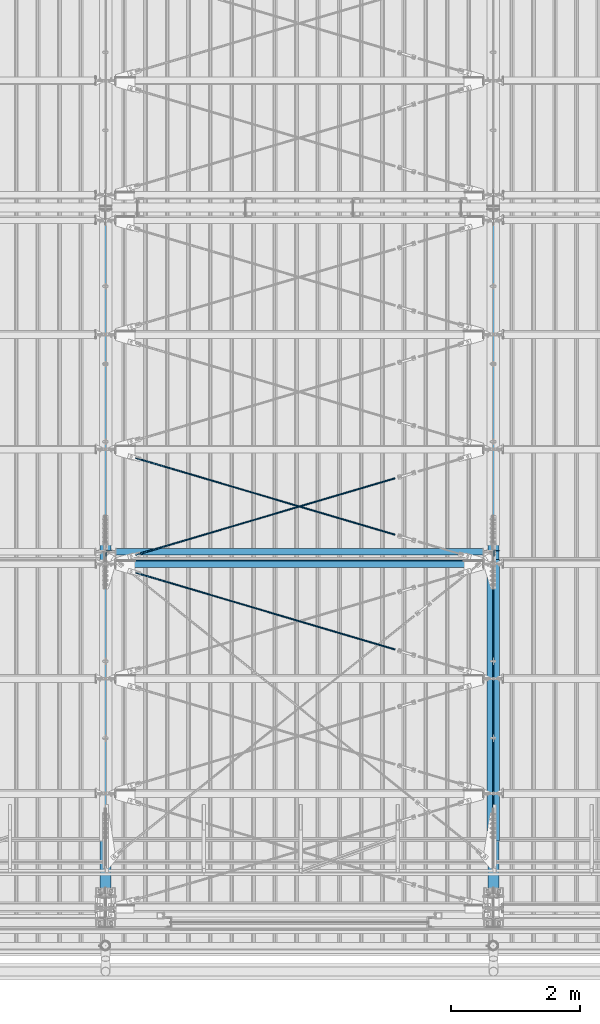
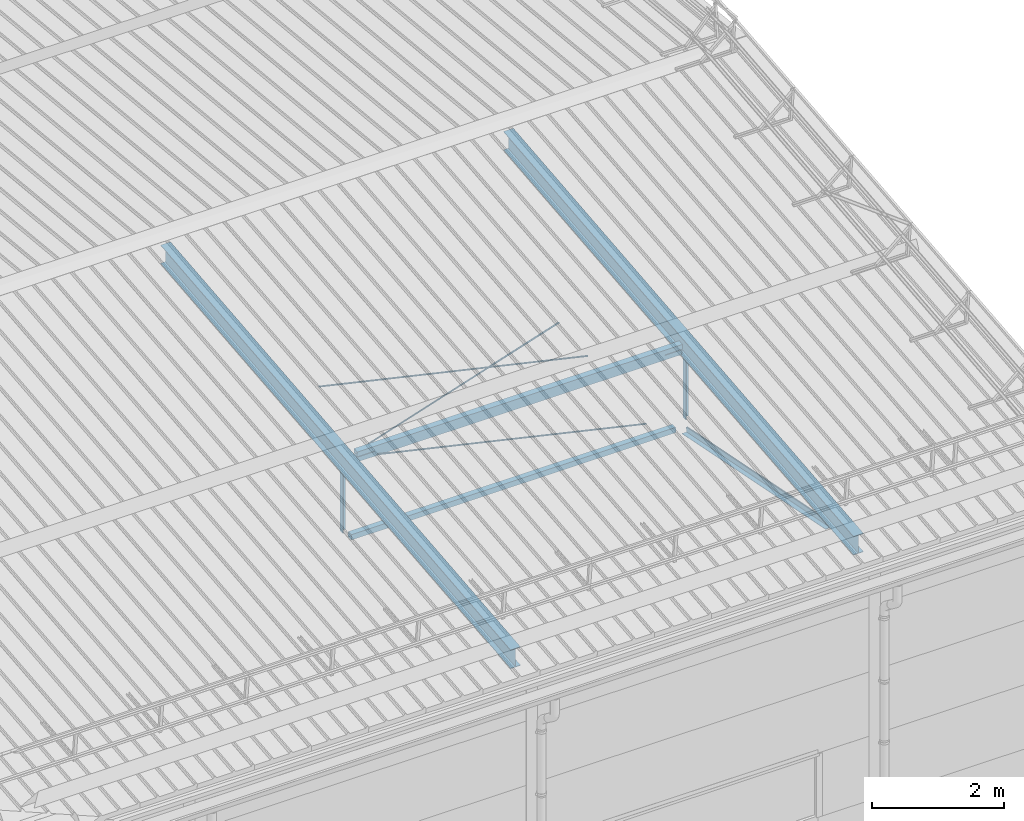
# One storey, part 275 of 709: 11 beams, 5 openings, 11 elements without a shape of their own.
"""IFC4 building model written with IfcOpenShell, lengths in millimetres."""

from ifc_helpers import new_model, si_unit, direction, frame, origin_with_axes, place, context, subcontext, project, spatial, line, indexed_curve, outline, extrude, polygons, material, element, aggregate, save


model = new_model("IFC4")

# Units and contexts
model_context = context("Model", 3, precision=0.2, world=origin_with_axes(), true_north=direction((0.0, 1.0)))
body_context = subcontext(model_context, "Body", "Model", "MODEL_VIEW")
reference_context = subcontext(model_context, "Reference", "Model", "MODEL_VIEW")
ifc_project = project(units=[si_unit("LENGTHUNIT", "METRE", prefix="MILLI"), si_unit("AREAUNIT", "SQUARE_METRE"), si_unit("VOLUMEUNIT", "CUBIC_METRE"), si_unit("MASSUNIT", "GRAM", prefix="KILO"), si_unit("TIMEUNIT", "SECOND"), si_unit("PLANEANGLEUNIT", "RADIAN"), si_unit("SOLIDANGLEUNIT", "STERADIAN"), si_unit("THERMODYNAMICTEMPERATUREUNIT", "DEGREE_CELSIUS"), si_unit("LUMINOUSINTENSITYUNIT", "LUMEN")], contexts=[model_context])

# Site, building, storey
site_placement = place(None, origin_with_axes())
site = spatial("IfcSite", under=ifc_project, at=site_placement, CompositionType="ELEMENT")
building_placement = place(site_placement, origin_with_axes())
building = spatial("IfcBuilding", under=site, at=building_placement, Name="Undefined", CompositionType="ELEMENT")
storey_placement = place(building_placement, origin_with_axes())
storey = spatial("IfcBuildingStorey", under=building, at=storey_placement, Name="Undefined", CompositionType="ELEMENT", Elevation=0.0)

# Assembly, beam
assembly_1_placement = place(storey_placement, frame((40000.0, 346.0, 7089.70002), z_axis=(1.0, 0.0, 0.0), x_axis=(0.0, 0.9950371902, 0.099503719)))
assembly_1 = element("IfcElementAssembly", 1, at=assembly_1_placement, inside=storey)
ifc_material_1 = material(Name="C355-5", Category="STEEL")
beam_1_placement = place(assembly_1_placement, origin_with_axes())
beam_1 = element("IfcBeam", 2, at=beam_1_placement, material=ifc_material_1, ObjectType="432", context=body_context, shape_type="Tessellation", body=[
    polygons([(3.80474, -173.0, -87.0), (4.70474, -164.0, -87.0), (10665.6128, -164.0, -87.0), (10664.7128, -173.0, -87.0), (4.70474, -164.0, -3.0), (10665.6128, -164.0, -3.0), (37.50474, 164.0, -3.0), (10698.4128, 164.0, -3.0), (37.50474, 164.0, -87.0), (10698.4128, 164.0, -87.0), (38.40474, 173.0, -87.0), (10699.3128, 173.0, -87.0), (38.40474, 173.0, 87.0), (10699.3128, 173.0, 87.0), (37.50474, 164.0, 87.0), (10698.4128, 164.0, 87.0), (37.50474, 164.0, 3.0), (10698.4128, 164.0, 3.0), (4.70474, -164.0, 3.0), (10665.6128, -164.0, 3.0), (4.70474, -164.0, 87.0), (10665.6128, -164.0, 87.0), (3.80474, -173.0, 87.0), (10664.7128, -173.0, 87.0)], [[[1, 2, 3, 4]], [[2, 5, 6, 3]], [[5, 7, 8, 6]], [[7, 9, 10, 8]], [[9, 11, 12, 10]], [[11, 13, 14, 12]], [[13, 15, 16, 14]], [[15, 17, 18, 16]], [[17, 19, 20, 18]], [[19, 21, 22, 20]], [[21, 23, 24, 22]], [[23, 1, 4, 24]], [[6, 8, 10, 12, 14, 16, 18, 20, 22, 24, 4, 3]], [[23, 21, 19, 17, 15, 13, 11, 9, 7, 5, 2, 1]]], closed=True),
])
aggregate(assembly_1, [beam_1])

assembly_2_placement = place(storey_placement, frame((40051.0, 5648.7, 7622.40002), z_axis=(0.0, -1.0, 0.0), x_axis=(0.0, 0.0, -1.0)))
assembly_2 = element("IfcElementAssembly", 3, at=assembly_2_placement, inside=storey)
ifc_material_2 = material(Name="C345-5", Category="STEEL")
beam_2_placement = place(assembly_2_placement, origin_with_axes())
beam_2 = element("IfcBeam", 4, at=beam_2_placement, material=ifc_material_2, ObjectType="436", context=body_context, shape_type="Tessellation", body=[
    polygons([(199.0491, -45.0, -45.0), (199.0491, 45.0, -45.0), (1412.4, 45.0, -45.0), (1412.4, -45.0, -45.0), (199.0491, 45.0, -39.0), (1412.4, 45.0, -39.0), (199.0491, -39.0, -39.0), (1412.4, -39.0, -39.0), (199.0491, -39.0, 45.0), (1412.4, -39.0, 45.0), (199.0491, -45.0, 45.0), (1412.4, -45.0, 45.0)], [[[1, 2, 3, 4]], [[2, 5, 6, 3]], [[5, 7, 8, 6]], [[7, 9, 10, 8]], [[9, 11, 12, 10]], [[11, 1, 4, 12]], [[6, 8, 10, 12, 4, 3]], [[11, 9, 7, 5, 2, 1]]], closed=True),
])
aggregate(assembly_2, [beam_2])

assembly_3_placement = place(storey_placement, frame((46000.0, 346.0, 7089.70002), z_axis=(1.0, 0.0, 0.0), x_axis=(0.0, 0.9950371902, 0.099503719)))
assembly_3 = element("IfcElementAssembly", 5, at=assembly_3_placement, inside=storey)
beam_3_placement = place(assembly_3_placement, origin_with_axes())
beam_3 = element("IfcBeam", 6, at=beam_3_placement, material=ifc_material_1, ObjectType="432", context=body_context, shape_type="Tessellation", body=[
    polygons([(3.80474, -173.0, -87.0), (4.70474, -164.0, -87.0), (10665.6128, -164.0, -87.0), (10664.7128, -173.0, -87.0), (4.70474, -164.0, -3.0), (10665.6128, -164.0, -3.0), (37.50474, 164.0, -3.0), (10698.4128, 164.0, -3.0), (37.50474, 164.0, -87.0), (10698.4128, 164.0, -87.0), (38.40474, 173.0, -87.0), (10699.3128, 173.0, -87.0), (38.40474, 173.0, 87.0), (10699.3128, 173.0, 87.0), (37.50474, 164.0, 87.0), (10698.4128, 164.0, 87.0), (37.50474, 164.0, 3.0), (10698.4128, 164.0, 3.0), (4.70474, -164.0, 3.0), (10665.6128, -164.0, 3.0), (4.70474, -164.0, 87.0), (10665.6128, -164.0, 87.0), (3.80474, -173.0, 87.0), (10664.7128, -173.0, 87.0)], [[[1, 2, 3, 4]], [[2, 5, 6, 3]], [[5, 7, 8, 6]], [[7, 9, 10, 8]], [[9, 11, 12, 10]], [[11, 13, 14, 12]], [[13, 15, 16, 14]], [[15, 17, 18, 16]], [[17, 19, 20, 18]], [[19, 21, 22, 20]], [[21, 23, 24, 22]], [[23, 1, 4, 24]], [[6, 8, 10, 12, 14, 16, 18, 20, 22, 24, 4, 3]], [[23, 21, 19, 17, 15, 13, 11, 9, 7, 5, 2, 1]]], closed=True),
])
aggregate(assembly_3, [beam_3])

assembly_4_placement = place(storey_placement, frame((45949.0, 350.0596, 7109.99804), z_axis=(0.0, 0.1961161349, 0.9805806757), x_axis=(0.0, 0.9805806757, -0.1961161349)))
assembly_4 = element("IfcElementAssembly", 7, at=assembly_4_placement, inside=storey)
beam_4_placement = place(assembly_4_placement, origin_with_axes())
beam_4 = element("IfcBeam", 8, at=beam_4_placement, material=ifc_material_2, ObjectType="435", context=body_context, shape_type="Tessellation", body=[
    polygons([(873.96605, -45.0, -45.0), (873.96605, 45.0, -45.0), (5317.375, 45.0, -45.0), (5317.375, -45.0, -45.0), (873.96605, 45.0, -39.0), (5317.375, 45.0, -39.0), (873.96605, -39.0, -39.0), (5317.375, -39.0, -39.0), (873.96605, -39.0, 45.0), (5317.375, -39.0, 45.0), (873.96605, -45.0, 45.0), (5317.375, -45.0, 45.0)], [[[1, 2, 3, 4]], [[2, 5, 6, 3]], [[5, 7, 8, 6]], [[7, 9, 10, 8]], [[9, 11, 12, 10]], [[11, 1, 4, 12]], [[6, 8, 10, 12, 4, 3]], [[11, 9, 7, 5, 2, 1]]], closed=True),
])
aggregate(assembly_4, [beam_4])

assembly_5_placement = place(storey_placement, frame((46051.0, 5677.0596, 6044.59804), z_axis=(0.0, 0.1961161349, 0.9805806757), x_axis=(0.0, -0.9805806757, 0.1961161349)))
assembly_5 = element("IfcElementAssembly", 9, at=assembly_5_placement, inside=storey)
beam_5_placement = place(assembly_5_placement, origin_with_axes())
beam_5 = element("IfcBeam", 10, at=beam_5_placement, material=ifc_material_2, ObjectType="435", context=body_context, shape_type="Tessellation", body=[
    polygons([(115.12039, -45.0, -45.0), (115.12039, 45.0, -45.0), (4558.52934, 45.0, -45.0), (4558.52934, -45.0, -45.0), (115.12039, 45.0, -39.0), (4558.52934, 45.0, -39.0), (115.12039, -39.0, -39.0), (4558.52934, -39.0, -39.0), (115.12039, -39.0, 45.0), (4558.52934, -39.0, 45.0), (115.12039, -45.0, 45.0), (4558.52934, -45.0, 45.0)], [[[1, 2, 3, 4]], [[2, 5, 6, 3]], [[5, 7, 8, 6]], [[7, 9, 10, 8]], [[9, 11, 12, 10]], [[11, 1, 4, 12]], [[6, 8, 10, 12, 4, 3]], [[11, 9, 7, 5, 2, 1]]], closed=True),
])
aggregate(assembly_5, [beam_5])

assembly_6_placement = place(storey_placement, frame((46051.0, 5648.7, 7622.40002), z_axis=(0.0, -1.0, 0.0), x_axis=(0.0, 0.0, -1.0)))
assembly_6 = element("IfcElementAssembly", 11, at=assembly_6_placement, inside=storey)
beam_6_placement = place(assembly_6_placement, origin_with_axes())
beam_6 = element("IfcBeam", 12, at=beam_6_placement, material=ifc_material_2, ObjectType="436", context=body_context, shape_type="Tessellation", body=[
    polygons([(199.0491, -45.0, -45.0), (199.0491, 45.0, -45.0), (1412.4, 45.0, -45.0), (1412.4, -45.0, -45.0), (199.0491, 45.0, -39.0), (1412.4, 45.0, -39.0), (199.0491, -39.0, -39.0), (1412.4, -39.0, -39.0), (199.0491, -39.0, 45.0), (1412.4, -39.0, 45.0), (199.0491, -45.0, 45.0), (1412.4, -45.0, 45.0)], [[[1, 2, 3, 4]], [[2, 5, 6, 3]], [[5, 7, 8, 6]], [[7, 9, 10, 8]], [[9, 11, 12, 10]], [[11, 1, 4, 12]], [[6, 8, 10, 12, 4, 3]], [[11, 9, 7, 5, 2, 1]]], closed=True),
])
aggregate(assembly_6, [beam_6])

assembly_7_placement = place(storey_placement, frame((40000.0, 5673.0, 6074.30002), z_axis=(0.0, -1.0, 0.0), x_axis=(1.0, 0.0, 0.0)))
assembly_7 = element("IfcElementAssembly", 13, at=assembly_7_placement, inside=storey)
ifc_material_3 = material(Name="C355", Category="STEEL")
beam_7_placement = place(assembly_7_placement, origin_with_axes())
beam_7 = element("IfcBeam", 14, at=beam_7_placement, material=ifc_material_3, ObjectType="557", context=body_context, shape_type="Tessellation", body=[
    polygons([(162.0, -47.0, -47.0), (162.0, -47.0, 47.0), (5838.0, -47.0, 47.0), (5838.0, -47.0, -47.0), (162.0, 47.0, 47.0), (5838.0, 47.0, 47.0), (162.0, 47.0, -47.0), (5838.0, 47.0, -47.0), (162.0, -50.0, -50.0), (162.0, 50.0, -50.0), (5838.0, 50.0, -50.0), (5838.0, -50.0, -50.0), (162.0, 50.0, 50.0), (5838.0, 50.0, 50.0), (162.0, -50.0, 50.0), (5838.0, -50.0, 50.0)], [[[1, 2, 3, 4]], [[2, 5, 6, 3]], [[5, 7, 8, 6]], [[7, 1, 4, 8]], [[9, 10, 11, 12]], [[10, 13, 14, 11]], [[13, 15, 16, 14]], [[15, 9, 12, 16]], [[14, 16, 12, 11], [6, 8, 4, 3]], [[15, 13, 10, 9], [7, 5, 2, 1]]], closed=True),
])
aggregate(assembly_7, [beam_7])

# Assembly, beam, voiding feature
assembly_8_placement = place(storey_placement, frame((40000.0, 5489.2536, 7685.42938), z_axis=(-0.2852311229, -0.9537021177, -0.0953702118), x_axis=(0.9584587662, -0.2838155751, -0.028381558)))
assembly_8 = element("IfcElementAssembly", 15, at=assembly_8_placement, inside=storey)
beam_8_placement = place(assembly_8_placement, origin_with_axes())
beam_8 = element("IfcBeam", 16, at=beam_8_placement, material=ifc_material_1, ObjectType="570", context=body_context, shape_type="Tessellation", body=[
    polygons([(4850.05021, 7.36122, 4.25), (4850.05021, 6.01041, 6.01041), (4850.05021, 4.25, 7.36121), (4850.05021, 2.19996, 8.21037), (4850.05021, 0.0, 8.5), (4850.05021, -2.19996, 8.21037), (4850.05021, -4.25, 7.36121), (4850.05021, -6.01041, 6.01041), (4850.05021, -7.36121, 4.25), (4850.05021, -8.21037, 2.19996), (4850.05021, -8.5, 0.0), (4850.05021, -8.21037, -2.19996), (4850.05021, -7.36121, -4.25), (4850.05021, -6.01041, -6.01041), (4850.05021, -4.25, -7.36122), (4850.05021, -2.19996, -8.21037), (4850.05021, 0.0, -8.5), (4850.05021, 2.19996, -8.21037), (4850.05021, 4.25, -7.36122), (4850.05021, 6.01041, -6.01041), (4850.05021, 7.36122, -4.25), (4850.05021, 8.21037, -2.19996), (4850.05021, 8.5, 0.0), (4850.05021, 8.21037, 2.19996), (4670.05021, 8.21037, 2.19996), (4670.05021, 7.36122, 4.25), (4670.05021, 6.01041, 6.01041), (4670.05021, 4.25, 7.36121), (4670.05021, 2.19996, 8.21037), (4670.05021, 0.0, 8.5), (4670.05021, -2.19996, 8.21037), (4670.05021, -4.25, 7.36121), (4670.05021, -6.01041, 6.01041), (4670.05021, -7.36121, 4.25), (4670.05021, -8.21037, 2.19996), (4670.05021, -8.5, 0.0), (4670.05021, -8.21037, -2.19996), (4670.05021, -7.36121, -4.25), (4670.05021, -6.01041, -6.01041), (4670.05021, -4.25, -7.36122), (4670.05021, -2.19996, -8.21037), (4670.05021, 0.0, -8.5), (4670.05021, 2.19996, -8.21037), (4670.05021, 4.25, -7.36122), (4670.05021, 6.01041, -6.01041), (4670.05021, 7.36122, -4.25), (4670.05021, 8.21037, -2.19996), (4670.05021, 8.5, 0.0), (4670.05021, 10.0, 0.0), (4670.05021, 9.65926, 2.58819), (4670.05021, 8.66025, 5.0), (4670.05021, 7.07107, 7.07107), (4670.05021, 5.0, 8.66025), (4670.05021, 2.58819, 9.65926), (4670.05021, 0.0, 10.0), (4670.05021, -2.58819, 9.65926), (4670.05021, -5.0, 8.66025), (4670.05021, -7.07107, 7.07107), (4670.05021, -8.66025, 5.0), (4670.05021, -9.65926, 2.58819), (4670.05021, -10.0, 0.0), (4670.05021, -9.65926, -2.58819), (4670.05021, -8.66025, -5.0), (4670.05021, -7.07107, -7.07107), (4670.05021, -5.0, -8.66025), (4670.05021, -2.58819, -9.65926), (4670.05021, 0.0, -10.0), (4670.05021, 2.58819, -9.65926), (4670.05021, 5.0, -8.66025), (4670.05021, 7.07107, -7.07107), (4670.05021, 8.66025, -5.0), (4670.05021, 9.65926, -2.58819), (483.0251, 2.58819, 9.65926), (483.0251, 5.0, 8.66025), (483.0251, 7.07107, 7.07107), (483.0251, 8.66025, 5.0), (483.0251, 9.65926, 2.58819), (483.0251, 10.0, 0.0), (483.0251, 9.65926, -2.58819), (483.0251, 8.66025, -5.0), (483.0251, 7.07107, -7.07107), (483.0251, 5.0, -8.66025), (483.0251, 2.58819, -9.65926), (483.0251, 0.0, -10.0), (483.0251, -2.58819, -9.65926), (483.0251, -5.0, -8.66025), (483.0251, -7.07107, -7.07107), (483.0251, -8.66025, -5.0), (483.0251, -9.65926, -2.58819), (483.0251, -10.0, 0.0), (483.0251, -9.65926, 2.58819), (483.0251, -8.66025, 5.0), (483.0251, -7.07107, 7.07107), (483.0251, -5.0, 8.66025), (483.0251, -2.58819, 9.65926), (483.0251, 0.0, 10.0)], [[[1, 2, 3, 4, 5, 6, 7, 8, 9, 10, 11, 12, 13, 14, 15, 16, 17, 18, 19, 20, 21, 22, 23, 24]], [[24, 25, 26, 1]], [[1, 26, 27, 2]], [[2, 27, 28, 3]], [[3, 28, 29, 4]], [[4, 29, 30, 5]], [[5, 30, 31, 6]], [[6, 31, 32, 7]], [[7, 32, 33, 8]], [[8, 33, 34, 9]], [[9, 34, 35, 10]], [[10, 35, 36, 11]], [[11, 36, 37, 12]], [[12, 37, 38, 13]], [[13, 38, 39, 14]], [[14, 39, 40, 15]], [[15, 40, 41, 16]], [[16, 41, 42, 17]], [[17, 42, 43, 18]], [[18, 43, 44, 19]], [[19, 44, 45, 20]], [[20, 45, 46, 21]], [[21, 46, 47, 22]], [[22, 47, 48, 23]], [[23, 48, 25, 24]], [[49, 50, 51, 52, 53, 54, 55, 56, 57, 58, 59, 60, 61, 62, 63, 64, 65, 66, 67, 68, 69, 70, 71, 72], [47, 46, 45, 44, 43, 42, 41, 40, 39, 38, 37, 36, 35, 34, 33, 32, 31, 30, 29, 28, 27, 26, 25, 48]], [[73, 74, 75, 76, 77, 78, 79, 80, 81, 82, 83, 84, 85, 86, 87, 88, 89, 90, 91, 92, 93, 94, 95, 96]], [[79, 78, 49, 72]], [[80, 79, 72, 71]], [[81, 80, 71, 70]], [[82, 81, 70, 69]], [[83, 82, 69, 68]], [[84, 83, 68, 67]], [[85, 84, 67, 66]], [[86, 85, 66, 65]], [[87, 86, 65, 64]], [[88, 87, 64, 63]], [[89, 88, 63, 62]], [[90, 89, 62, 61]], [[91, 90, 61, 60]], [[92, 91, 60, 59]], [[93, 92, 59, 58]], [[94, 93, 58, 57]], [[95, 94, 57, 56]], [[96, 95, 56, 55]], [[73, 96, 55, 54]], [[74, 73, 54, 53]], [[75, 74, 53, 52]], [[76, 75, 52, 51]], [[77, 76, 51, 50]], [[78, 77, 50, 49]]], closed=True),
])
voiding_feature_1_placement = place(beam_8_placement, frame((4850.05021, 0.0, 0.0), z_axis=(0.0, 1.0, 0.0), x_axis=(-1.0, 0.0, 0.0)))
element("IfcVoidingFeature", 17, at=voiding_feature_1_placement, cuts=beam_8, PredefinedType="HOLE", context=reference_context, identifier="Reference", shape_type="SolidModel", body=[
    extrude(outline(indexed_curve([(10.5, 0.0), (10.14222, 2.7176), (9.09327, 5.25), (7.42462, 7.42462), (5.25, 9.09327), (2.7176, 10.14222), (0.0, 10.5), (-2.7176, 10.14222), (-5.25, 9.09327), (-7.42462, 7.42462), (-9.09327, 5.25), (-10.14222, 2.7176), (-10.5, 0.0), (-10.14222, -2.7176), (-9.09327, -5.25), (-7.42462, -7.42462), (-5.25, -9.09327), (-2.7176, -10.14222), (0.0, -10.5), (2.7176, -10.14222), (5.25, -9.09327), (7.42462, -7.42462), (9.09327, -5.25), (10.14222, -2.7176)], segments=[line(1, 2, 3, 4, 5, 6, 7, 8, 9, 10, 11, 12, 13, 14, 15, 16, 17, 18, 19, 20, 21, 22, 23, 24, 1)])), frame((0.0, 0.0, 0.0), z_axis=(-1.0, 0.0, 0.0), x_axis=(0.0, 0.0, 1.0)), (0.0, 0.0, -1.0), 180.0),
])
aggregate(assembly_8, [beam_8])

assembly_9_placement = place(storey_placement, frame((40000.0, 5489.2536, 7685.42938), z_axis=(0.2847296511, -0.9538504697, -0.095385047), x_axis=(0.9586078582, 0.2833165921, 0.028331659)))
assembly_9 = element("IfcElementAssembly", 18, at=assembly_9_placement, inside=storey)
beam_9_placement = place(assembly_9_placement, origin_with_axes())
beam_9 = element("IfcBeam", 19, at=beam_9_placement, material=ifc_material_1, ObjectType="572", context=body_context, shape_type="Tessellation", body=[
    polygons([(4849.07659, 7.36122, 4.25), (4849.07659, 6.01041, 6.01041), (4849.07659, 4.25, 7.36122), (4849.07659, 2.19996, 8.21037), (4849.07659, 0.0, 8.5), (4849.07659, -2.19996, 8.21037), (4849.07659, -4.25, 7.36122), (4849.07659, -6.01041, 6.01041), (4849.07659, -7.36121, 4.25), (4849.07659, -8.21037, 2.19996), (4849.07659, -8.5, 0.0), (4849.07659, -8.21037, -2.19996), (4849.07659, -7.36121, -4.25), (4849.07659, -6.01041, -6.01041), (4849.07659, -4.25, -7.36122), (4849.07659, -2.19996, -8.21037), (4849.07659, 0.0, -8.5), (4849.07659, 2.19996, -8.21037), (4849.07659, 4.25, -7.36122), (4849.07659, 6.01041, -6.01041), (4849.07659, 7.36122, -4.25), (4849.07659, 8.21037, -2.19996), (4849.07659, 8.5, 0.0), (4849.07659, 8.21037, 2.19996), (4669.07659, 8.21037, 2.19996), (4669.07659, 7.36122, 4.25), (4669.07659, 6.01041, 6.01041), (4669.07659, 4.25, 7.36122), (4669.07659, 2.19996, 8.21037), (4669.07659, 0.0, 8.5), (4669.07659, -2.19996, 8.21037), (4669.07659, -4.25, 7.36122), (4669.07659, -6.01041, 6.01041), (4669.07659, -7.36121, 4.25), (4669.07659, -8.21037, 2.19996), (4669.07659, -8.5, 0.0), (4669.07659, -8.21037, -2.19996), (4669.07659, -7.36121, -4.25), (4669.07659, -6.01041, -6.01041), (4669.07659, -4.25, -7.36122), (4669.07659, -2.19996, -8.21037), (4669.07659, 0.0, -8.5), (4669.07659, 2.19996, -8.21037), (4669.07659, 4.25, -7.36122), (4669.07659, 6.01041, -6.01041), (4669.07659, 7.36122, -4.25), (4669.07659, 8.21037, -2.19996), (4669.07659, 8.5, 0.0), (4669.07659, 10.0, 0.0), (4669.07659, 9.65926, 2.58819), (4669.07659, 8.66025, 5.0), (4669.07659, 7.07107, 7.07107), (4669.07659, 5.0, 8.66025), (4669.07659, 2.58819, 9.65926), (4669.07659, 0.0, 10.0), (4669.07659, -2.58819, 9.65926), (4669.07659, -5.0, 8.66025), (4669.07659, -7.07107, 7.07107), (4669.07659, -8.66025, 5.0), (4669.07659, -9.65926, 2.58819), (4669.07659, -10.0, 0.0), (4669.07659, -9.65926, -2.58819), (4669.07659, -8.66025, -5.0), (4669.07659, -7.07107, -7.07107), (4669.07659, -5.0, -8.66025), (4669.07659, -2.58819, -9.65926), (4669.07659, 0.0, -10.0), (4669.07659, 2.58819, -9.65926), (4669.07659, 5.0, -8.66025), (4669.07659, 7.07107, -7.07107), (4669.07659, 8.66025, -5.0), (4669.07659, 9.65926, -2.58819), (483.68279, 2.58819, 9.65926), (483.68279, 5.0, 8.66025), (483.68279, 7.07107, 7.07107), (483.68279, 8.66025, 5.0), (483.68279, 9.65926, 2.58819), (483.68279, 10.0, 0.0), (483.68279, 9.65926, -2.58819), (483.68279, 8.66025, -5.0), (483.68279, 7.07107, -7.07107), (483.68279, 5.0, -8.66025), (483.68279, 2.58819, -9.65926), (483.68279, 0.0, -10.0), (483.68279, -2.58819, -9.65926), (483.68279, -5.0, -8.66025), (483.68279, -7.07107, -7.07107), (483.68279, -8.66025, -5.0), (483.68279, -9.65926, -2.58819), (483.68279, -10.0, 0.0), (483.68279, -9.65926, 2.58819), (483.68279, -8.66025, 5.0), (483.68279, -7.07107, 7.07107), (483.68279, -5.0, 8.66025), (483.68279, -2.58819, 9.65926), (483.68279, 0.0, 10.0)], [[[1, 2, 3, 4, 5, 6, 7, 8, 9, 10, 11, 12, 13, 14, 15, 16, 17, 18, 19, 20, 21, 22, 23, 24]], [[24, 25, 26, 1]], [[1, 26, 27, 2]], [[2, 27, 28, 3]], [[3, 28, 29, 4]], [[4, 29, 30, 5]], [[5, 30, 31, 6]], [[6, 31, 32, 7]], [[7, 32, 33, 8]], [[8, 33, 34, 9]], [[9, 34, 35, 10]], [[10, 35, 36, 11]], [[11, 36, 37, 12]], [[12, 37, 38, 13]], [[13, 38, 39, 14]], [[14, 39, 40, 15]], [[15, 40, 41, 16]], [[16, 41, 42, 17]], [[17, 42, 43, 18]], [[18, 43, 44, 19]], [[19, 44, 45, 20]], [[20, 45, 46, 21]], [[21, 46, 47, 22]], [[22, 47, 48, 23]], [[23, 48, 25, 24]], [[49, 50, 51, 52, 53, 54, 55, 56, 57, 58, 59, 60, 61, 62, 63, 64, 65, 66, 67, 68, 69, 70, 71, 72], [47, 46, 45, 44, 43, 42, 41, 40, 39, 38, 37, 36, 35, 34, 33, 32, 31, 30, 29, 28, 27, 26, 25, 48]], [[73, 74, 75, 76, 77, 78, 79, 80, 81, 82, 83, 84, 85, 86, 87, 88, 89, 90, 91, 92, 93, 94, 95, 96]], [[79, 78, 49, 72]], [[80, 79, 72, 71]], [[81, 80, 71, 70]], [[82, 81, 70, 69]], [[83, 82, 69, 68]], [[84, 83, 68, 67]], [[85, 84, 67, 66]], [[86, 85, 66, 65]], [[87, 86, 65, 64]], [[88, 87, 64, 63]], [[89, 88, 63, 62]], [[90, 89, 62, 61]], [[91, 90, 61, 60]], [[92, 91, 60, 59]], [[93, 92, 59, 58]], [[94, 93, 58, 57]], [[95, 94, 57, 56]], [[96, 95, 56, 55]], [[73, 96, 55, 54]], [[74, 73, 54, 53]], [[75, 74, 53, 52]], [[76, 75, 52, 51]], [[77, 76, 51, 50]], [[78, 77, 50, 49]]], closed=True),
])
voiding_feature_2_placement = place(beam_9_placement, frame((4849.07659, 0.0, 0.0), z_axis=(0.0, 1.0, 0.0), x_axis=(-1.0, 0.0, 0.0)))
element("IfcVoidingFeature", 20, at=voiding_feature_2_placement, cuts=beam_9, PredefinedType="HOLE", context=reference_context, identifier="Reference", shape_type="SolidModel", body=[
    extrude(outline(indexed_curve([(10.5, 0.0), (10.14222, 2.7176), (9.09327, 5.25), (7.42462, 7.42462), (5.25, 9.09327), (2.7176, 10.14222), (0.0, 10.5), (-2.7176, 10.14222), (-5.25, 9.09327), (-7.42462, 7.42462), (-9.09327, 5.25), (-10.14222, 2.7176), (-10.5, 0.0), (-10.14222, -2.7176), (-9.09327, -5.25), (-7.42462, -7.42462), (-5.25, -9.09327), (-2.7176, -10.14222), (0.0, -10.5), (2.7176, -10.14222), (5.25, -9.09327), (7.42462, -7.42462), (9.09327, -5.25), (10.14222, -2.7176)], segments=[line(1, 2, 3, 4, 5, 6, 7, 8, 9, 10, 11, 12, 13, 14, 15, 16, 17, 18, 19, 20, 21, 22, 23, 24, 1)])), frame((0.0, 0.0, 0.0), z_axis=(-1.0, 0.0, 0.0), x_axis=(0.0, 0.0, 1.0)), (0.0, 0.0, -1.0), 180.0),
])
aggregate(assembly_9, [beam_9])

assembly_10_placement = place(storey_placement, frame((40000.0, 7262.55385, 7862.7594), z_axis=(-0.2847296511, -0.9538504697, -0.095385047), x_axis=(0.9586078582, -0.2833165921, -0.028331659)))
assembly_10 = element("IfcElementAssembly", 21, at=assembly_10_placement, inside=storey)
beam_10_placement = place(assembly_10_placement, origin_with_axes())
beam_10 = element("IfcBeam", 22, at=beam_10_placement, material=ifc_material_1, ObjectType="572", context=body_context, shape_type="Tessellation", body=[
    polygons([(4849.07659, 7.36122, 4.25), (4849.07659, 6.01041, 6.01041), (4849.07659, 4.25, 7.36122), (4849.07659, 2.19996, 8.21037), (4849.07659, 0.0, 8.5), (4849.07659, -2.19996, 8.21037), (4849.07659, -4.25, 7.36122), (4849.07659, -6.01041, 6.01041), (4849.07659, -7.36121, 4.25), (4849.07659, -8.21037, 2.19996), (4849.07659, -8.5, 0.0), (4849.07659, -8.21037, -2.19996), (4849.07659, -7.36121, -4.25), (4849.07659, -6.01041, -6.01041), (4849.07659, -4.25, -7.36122), (4849.07659, -2.19996, -8.21037), (4849.07659, 0.0, -8.5), (4849.07659, 2.19996, -8.21037), (4849.07659, 4.25, -7.36122), (4849.07659, 6.01041, -6.01041), (4849.07659, 7.36122, -4.25), (4849.07659, 8.21037, -2.19996), (4849.07659, 8.5, 0.0), (4849.07659, 8.21037, 2.19996), (4669.07659, 8.21037, 2.19996), (4669.07659, 7.36122, 4.25), (4669.07659, 6.01041, 6.01041), (4669.07659, 4.25, 7.36122), (4669.07659, 2.19996, 8.21037), (4669.07659, 0.0, 8.5), (4669.07659, -2.19996, 8.21037), (4669.07659, -4.25, 7.36122), (4669.07659, -6.01041, 6.01041), (4669.07659, -7.36121, 4.25), (4669.07659, -8.21037, 2.19996), (4669.07659, -8.5, 0.0), (4669.07659, -8.21037, -2.19996), (4669.07659, -7.36121, -4.25), (4669.07659, -6.01041, -6.01041), (4669.07659, -4.25, -7.36122), (4669.07659, -2.19996, -8.21037), (4669.07659, 0.0, -8.5), (4669.07659, 2.19996, -8.21037), (4669.07659, 4.25, -7.36122), (4669.07659, 6.01041, -6.01041), (4669.07659, 7.36122, -4.25), (4669.07659, 8.21037, -2.19996), (4669.07659, 8.5, 0.0), (4669.07659, 10.0, 0.0), (4669.07659, 9.65926, 2.58819), (4669.07659, 8.66025, 5.0), (4669.07659, 7.07107, 7.07107), (4669.07659, 5.0, 8.66025), (4669.07659, 2.58819, 9.65926), (4669.07659, 0.0, 10.0), (4669.07659, -2.58819, 9.65926), (4669.07659, -5.0, 8.66025), (4669.07659, -7.07107, 7.07107), (4669.07659, -8.66025, 5.0), (4669.07659, -9.65926, 2.58819), (4669.07659, -10.0, 0.0), (4669.07659, -9.65926, -2.58819), (4669.07659, -8.66025, -5.0), (4669.07659, -7.07107, -7.07107), (4669.07659, -5.0, -8.66025), (4669.07659, -2.58819, -9.65926), (4669.07659, 0.0, -10.0), (4669.07659, 2.58819, -9.65926), (4669.07659, 5.0, -8.66025), (4669.07659, 7.07107, -7.07107), (4669.07659, 8.66025, -5.0), (4669.07659, 9.65926, -2.58819), (483.68279, 2.58819, 9.65926), (483.68279, 5.0, 8.66025), (483.68279, 7.07107, 7.07107), (483.68279, 8.66025, 5.0), (483.68279, 9.65926, 2.58819), (483.68279, 10.0, 0.0), (483.68279, 9.65926, -2.58819), (483.68279, 8.66025, -5.0), (483.68279, 7.07107, -7.07107), (483.68279, 5.0, -8.66025), (483.68279, 2.58819, -9.65926), (483.68279, 0.0, -10.0), (483.68279, -2.58819, -9.65926), (483.68279, -5.0, -8.66025), (483.68279, -7.07107, -7.07107), (483.68279, -8.66025, -5.0), (483.68279, -9.65926, -2.58819), (483.68279, -10.0, 0.0), (483.68279, -9.65926, 2.58819), (483.68279, -8.66025, 5.0), (483.68279, -7.07107, 7.07107), (483.68279, -5.0, 8.66025), (483.68279, -2.58819, 9.65926), (483.68279, 0.0, 10.0)], [[[1, 2, 3, 4, 5, 6, 7, 8, 9, 10, 11, 12, 13, 14, 15, 16, 17, 18, 19, 20, 21, 22, 23, 24]], [[24, 25, 26, 1]], [[1, 26, 27, 2]], [[2, 27, 28, 3]], [[3, 28, 29, 4]], [[4, 29, 30, 5]], [[5, 30, 31, 6]], [[6, 31, 32, 7]], [[7, 32, 33, 8]], [[8, 33, 34, 9]], [[9, 34, 35, 10]], [[10, 35, 36, 11]], [[11, 36, 37, 12]], [[12, 37, 38, 13]], [[13, 38, 39, 14]], [[14, 39, 40, 15]], [[15, 40, 41, 16]], [[16, 41, 42, 17]], [[17, 42, 43, 18]], [[18, 43, 44, 19]], [[19, 44, 45, 20]], [[20, 45, 46, 21]], [[21, 46, 47, 22]], [[22, 47, 48, 23]], [[23, 48, 25, 24]], [[49, 50, 51, 52, 53, 54, 55, 56, 57, 58, 59, 60, 61, 62, 63, 64, 65, 66, 67, 68, 69, 70, 71, 72], [47, 46, 45, 44, 43, 42, 41, 40, 39, 38, 37, 36, 35, 34, 33, 32, 31, 30, 29, 28, 27, 26, 25, 48]], [[73, 74, 75, 76, 77, 78, 79, 80, 81, 82, 83, 84, 85, 86, 87, 88, 89, 90, 91, 92, 93, 94, 95, 96]], [[79, 78, 49, 72]], [[80, 79, 72, 71]], [[81, 80, 71, 70]], [[82, 81, 70, 69]], [[83, 82, 69, 68]], [[84, 83, 68, 67]], [[85, 84, 67, 66]], [[86, 85, 66, 65]], [[87, 86, 65, 64]], [[88, 87, 64, 63]], [[89, 88, 63, 62]], [[90, 89, 62, 61]], [[91, 90, 61, 60]], [[92, 91, 60, 59]], [[93, 92, 59, 58]], [[94, 93, 58, 57]], [[95, 94, 57, 56]], [[96, 95, 56, 55]], [[73, 96, 55, 54]], [[74, 73, 54, 53]], [[75, 74, 53, 52]], [[76, 75, 52, 51]], [[77, 76, 51, 50]], [[78, 77, 50, 49]]], closed=True),
])
voiding_feature_3_placement = place(beam_10_placement, frame((4849.07659, 0.0, 0.0), z_axis=(0.0, 1.0, 0.0), x_axis=(-1.0, 0.0, 0.0)))
element("IfcVoidingFeature", 23, at=voiding_feature_3_placement, cuts=beam_10, PredefinedType="HOLE", context=reference_context, identifier="Reference", shape_type="SolidModel", body=[
    extrude(outline(indexed_curve([(10.5, 0.0), (10.14222, 2.7176), (9.09327, 5.25), (7.42462, 7.42462), (5.25, 9.09327), (2.7176, 10.14222), (0.0, 10.5), (-2.7176, 10.14222), (-5.25, 9.09327), (-7.42462, 7.42462), (-9.09327, 5.25), (-10.14222, 2.7176), (-10.5, 0.0), (-10.14222, -2.7176), (-9.09327, -5.25), (-7.42462, -7.42462), (-5.25, -9.09327), (-2.7176, -10.14222), (0.0, -10.5), (2.7176, -10.14222), (5.25, -9.09327), (7.42462, -7.42462), (9.09327, -5.25), (10.14222, -2.7176)], segments=[line(1, 2, 3, 4, 5, 6, 7, 8, 9, 10, 11, 12, 13, 14, 15, 16, 17, 18, 19, 20, 21, 22, 23, 24, 1)])), frame((0.0, 0.0, 0.0), z_axis=(-1.0, 0.0, 0.0), x_axis=(0.0, 0.0, 1.0)), (0.0, 0.0, -1.0), 180.0),
])
aggregate(assembly_10, [beam_10])

# Assembly, beam, voiding features
assembly_11_placement = place(storey_placement, frame((40000.0, 5490.04963, 7677.46908), z_axis=(0.0, 0.9950371902, 0.099503719), x_axis=(1.0, 0.0, 0.0)))
assembly_11 = element("IfcElementAssembly", 24, at=assembly_11_placement, inside=storey)
beam_11_placement = place(assembly_11_placement, origin_with_axes())
beam_11 = element("IfcBeam", 25, at=beam_11_placement, material=ifc_material_3, ObjectType="566", context=body_context, shape_type="Tessellation", body=[
    polygons([(5845.0, -5.0, 50.0), (5845.0, -5.0, 46.0), (5542.86046, -5.0, 46.0), (5542.84523, -5.0, 50.0), (5542.86046, 5.0, 46.0), (5542.84523, 5.0, 50.0), (5845.00055, 5.0, 50.0), (5845.0, 5.0, 46.0), (5845.0, -5.0, -46.0), (5845.0, -5.0, -50.0), (5543.22591, -5.0, -50.0), (5543.21068, -5.0, -46.0), (5543.22591, 5.0, -50.0), (5543.21068, 5.0, -46.0), (5845.00055, 5.0, -46.0), (5845.0, 5.0, -50.0), (155.0, 96.0, 46.0), (155.0, 96.0, -46.0), (5845.0, 96.0, -46.0), (5845.0, 96.0, 46.0), (5845.0, -96.0, 46.0), (155.0, -96.0, 46.0), (155.0, -5.0, 46.0), (457.13954, -5.0, 46.0), (457.13954, 5.0, 46.0), (155.0, 5.0, 46.0), (155.0, -96.0, -46.0), (5845.0, -96.0, -46.0), (155.0, 5.0, -46.0), (155.0, 5.0, -50.0), (456.7741, 5.0, -50.0), (456.78932, 5.0, -46.0), (456.7741, -5.0, -50.0), (456.78932, -5.0, -46.0), (155.0, -5.0, -50.0), (155.0, -5.0, -46.0), (155.0, -100.0, -50.0), (155.0, -100.0, 50.0), (155.0, -5.0, 50.0), (457.15477, -5.0, 50.0), (457.15477, 5.0, 50.0), (155.0, 5.0, 50.0), (155.0, 100.0, 50.0), (155.0, 100.0, -50.0), (5845.0, 100.0, 50.0), (5845.0, 100.0, -50.0), (5845.0, -100.0, -50.0), (5845.0, -100.0, 50.0)], [[[1, 2, 3, 4]], [[4, 3, 5, 6]], [[7, 6, 5, 8]], [[9, 10, 11, 12]], [[12, 11, 13, 14]], [[15, 14, 13, 16]], [[17, 18, 19, 20]], [[3, 2, 21, 22, 23, 24, 25, 26, 17, 20, 8, 5]], [[27, 22, 21, 28]], [[29, 30, 31, 32]], [[32, 31, 33, 34]], [[34, 33, 35, 36]], [[22, 27, 36, 35, 37, 38, 39, 23]], [[40, 24, 23, 39]], [[41, 25, 24, 40]], [[42, 26, 25, 41]], [[43, 44, 30, 29, 18, 17, 26, 42]], [[44, 43, 45, 46]], [[20, 19, 15, 16, 46, 45, 7, 8]], [[11, 10, 47, 37, 35, 33, 31, 30, 44, 46, 16, 13]], [[38, 37, 47, 48]], [[45, 43, 42, 41, 40, 39, 38, 48, 1, 4, 6, 7]], [[48, 47, 10, 9, 28, 21, 2, 1]], [[19, 18, 29, 32, 34, 36, 27, 28, 9, 12, 14, 15]]], closed=True),
])
voiding_feature_4_placement = place(beam_11_placement, frame((154.99945, 0.0, 92.98165), z_axis=(0.0, -1.0, 0.0), x_axis=(0.0, 0.0, -1.0)))
element("IfcVoidingFeature", 26, at=voiding_feature_4_placement, cuts=beam_11, Name="PLATE", PredefinedType="HOLE", context=reference_context, identifier="Reference", shape_type="SolidModel", body=[
    extrude(outline(indexed_curve([(0.0, 0.0), (186.05886, 0.0), (268.18146, 275.95562), (181.92017, 301.62642), (4.09476, 302.30336), (-82.17995, 276.67769)], segments=[line(1, 2, 3, 4, 5, 6, 1)])), frame((0.0, 0.0, 5.0), z_axis=(0.0, 0.0, 1.0), x_axis=(1.0, 0.0, 0.0)), (0.0, 0.0, -1.0), 10.0),
])
voiding_feature_5_placement = place(beam_11_placement, frame((5845.00055, 0.0, -93.07721), z_axis=(0.0, -1.0, 0.0), x_axis=(0.0, 0.0, 1.0)))
element("IfcVoidingFeature", 27, at=voiding_feature_5_placement, cuts=beam_11, Name="PLATE", PredefinedType="HOLE", context=reference_context, identifier="Reference", shape_type="SolidModel", body=[
    extrude(outline(indexed_curve([(0.0, 0.0), (186.05886, 0.0), (268.2388, 276.67769), (181.9641, 302.30336), (4.13868, 301.62642), (-82.1226, 275.95562)], segments=[line(1, 2, 3, 4, 5, 6, 1)])), frame((0.0, 0.0, 5.0), z_axis=(0.0, 0.0, 1.0), x_axis=(1.0, 0.0, 0.0)), (0.0, 0.0, -1.0), 10.0),
])
aggregate(assembly_11, [beam_11])

save(model, "model.ifc")
